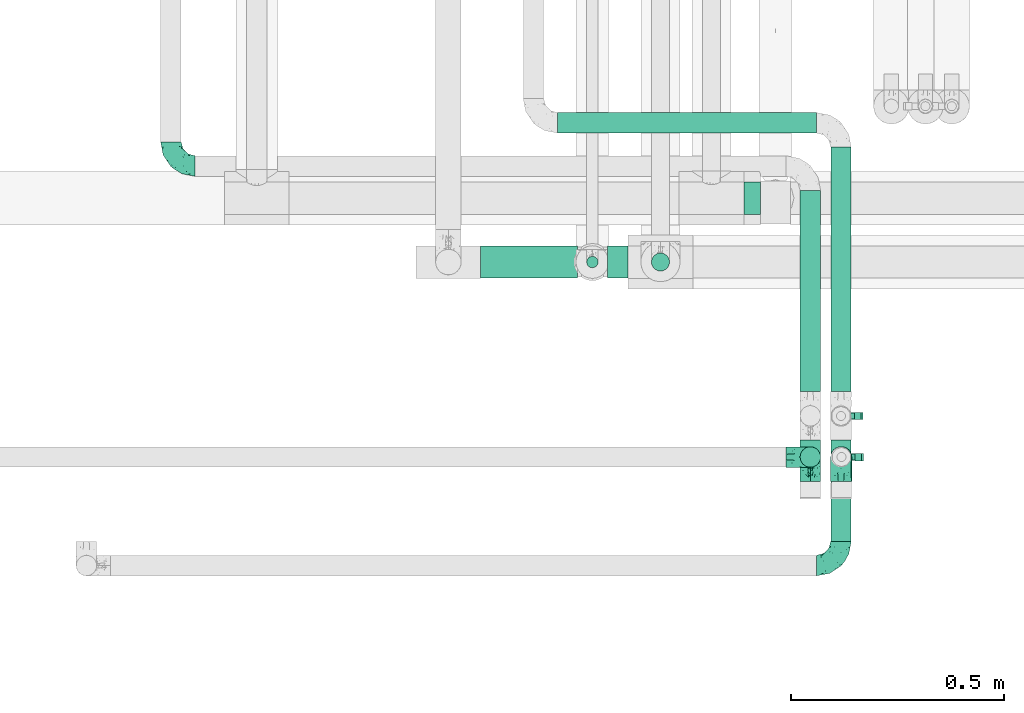
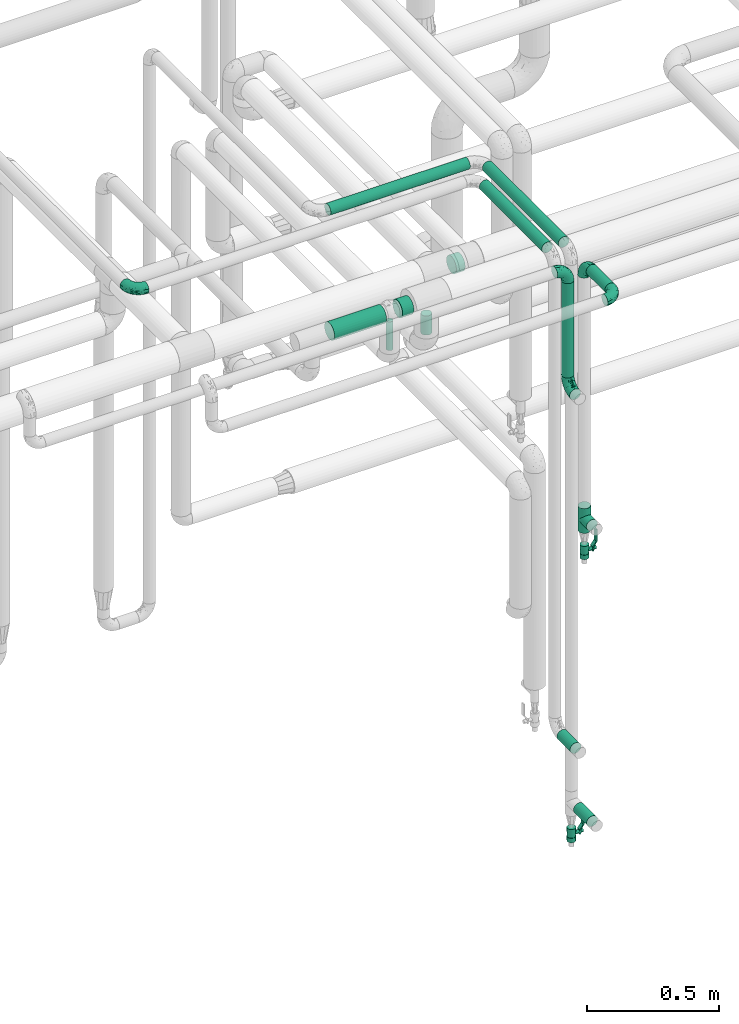
# One storey, part 689 of 827: 12 flow segments, 6 flow fittings, 2 flow controllers.
"""IFC2X3 building model written with IfcOpenShell, lengths in millimetres."""

from ifc_helpers import new_model, entity, si_unit, converted_unit, derived_unit, direction, frame, origin, origin_2d_with_axis, place, context, subcontext, project, spatial, polyline, circle, outline, extrude, faceted_brep, source, transform, mapped, material, material_list, type_object, type_shapes, element, save


model = new_model("IFC2X3")

# Units and contexts
model_context = context("Model", 3, precision=0.01, world=origin(), true_north=direction((6.12303176911189e-17, 1.0)))
body_context = subcontext(model_context, "Body", "Model", "MODEL_VIEW")
ifc_project = project(units=[si_unit("LENGTHUNIT", "METRE", prefix="MILLI"), si_unit("AREAUNIT", "SQUARE_METRE"), si_unit("VOLUMEUNIT", "CUBIC_METRE"), converted_unit("PLANEANGLEUNIT", "DEGREE", entity("IfcRatioMeasure", 0.0174532925199433), si_unit("PLANEANGLEUNIT", "RADIAN"), dimensions=[0, 0, 0, 0, 0, 0, 0]), si_unit("MASSUNIT", "GRAM", prefix="KILO"), derived_unit("MASSDENSITYUNIT", [(si_unit("MASSUNIT", "GRAM", prefix="KILO"), 1), (si_unit("LENGTHUNIT", "METRE"), -3)]), derived_unit("MOMENTOFINERTIAUNIT", [(si_unit("LENGTHUNIT", "METRE"), 4)]), si_unit("TIMEUNIT", "SECOND"), si_unit("FREQUENCYUNIT", "HERTZ"), si_unit("THERMODYNAMICTEMPERATUREUNIT", "DEGREE_CELSIUS"), derived_unit("THERMALTRANSMITTANCEUNIT", [(si_unit("MASSUNIT", "GRAM", prefix="KILO"), 1), (si_unit("THERMODYNAMICTEMPERATUREUNIT", "KELVIN"), -1), (si_unit("TIMEUNIT", "SECOND"), -3)]), derived_unit("VOLUMETRICFLOWRATEUNIT", [(si_unit("LENGTHUNIT", "METRE"), 3), (si_unit("TIMEUNIT", "SECOND"), -1)]), derived_unit("MASSFLOWRATEUNIT", [(si_unit("MASSUNIT", "GRAM", prefix="KILO"), 1), (si_unit("TIMEUNIT", "SECOND"), -1)]), derived_unit("ROTATIONALFREQUENCYUNIT", [(si_unit("TIMEUNIT", "SECOND"), -1)]), si_unit("ELECTRICCURRENTUNIT", "AMPERE"), si_unit("ELECTRICVOLTAGEUNIT", "VOLT"), si_unit("POWERUNIT", "WATT"), si_unit("FORCEUNIT", "NEWTON", prefix="KILO"), si_unit("ILLUMINANCEUNIT", "LUX"), si_unit("LUMINOUSFLUXUNIT", "LUMEN"), si_unit("LUMINOUSINTENSITYUNIT", "CANDELA"), derived_unit("USERDEFINED", [(si_unit("MASSUNIT", "GRAM", prefix="KILO"), -1), (si_unit("LENGTHUNIT", "METRE"), -2), (si_unit("TIMEUNIT", "SECOND"), 3), (si_unit("LUMINOUSFLUXUNIT", "LUMEN"), 1)]), derived_unit("LINEARVELOCITYUNIT", [(si_unit("LENGTHUNIT", "METRE"), 1), (si_unit("TIMEUNIT", "SECOND"), -1)]), si_unit("PRESSUREUNIT", "PASCAL"), derived_unit("USERDEFINED", [(si_unit("LENGTHUNIT", "METRE"), -2), (si_unit("MASSUNIT", "GRAM", prefix="KILO"), 1), (si_unit("TIMEUNIT", "SECOND"), -2)]), derived_unit("LINEARFORCEUNIT", [(si_unit("MASSUNIT", "GRAM", prefix="KILO"), 1), (si_unit("LENGTHUNIT", "METRE"), 1), (si_unit("TIMEUNIT", "SECOND"), -2), (si_unit("LENGTHUNIT", "METRE"), -1)]), derived_unit("PLANARFORCEUNIT", [(si_unit("MASSUNIT", "GRAM", prefix="KILO"), 1), (si_unit("LENGTHUNIT", "METRE"), 1), (si_unit("TIMEUNIT", "SECOND"), -2), (si_unit("LENGTHUNIT", "METRE"), -2)])], contexts=[model_context])

# Site, building, storey
site_placement = place(None, origin())
site = spatial("IfcSite", under=ifc_project, at=site_placement, CompositionType="ELEMENT")
building_placement = place(site_placement, origin())
building = spatial("IfcBuilding", under=site, at=building_placement, CompositionType="ELEMENT")
storey_placement = place(building_placement, frame((0.0, 0.0, 28200.0)))
storey = spatial("IfcBuildingStorey", under=building, at=storey_placement, Name="08", CompositionType="ELEMENT", Elevation=28200.0)

# Flow segments
pipe_segment_type = type_object("IfcPipeSegmentType", PredefinedType="NOTDEFINED")
flow_segment_1_placement = place(storey_placement, frame((54468.31, 15266.32, 2973.65)))
element("IfcFlowSegment", 1, at=flow_segment_1_placement, inside=storey, type_object=pipe_segment_type, context=body_context, shape_type="SweptSolid", body=[
    extrude(circle(Radius=24.0, at=origin_2d_with_axis()), frame((25.6, 0.0, 25.6), z_axis=(0.0, 1.0, 0.0), x_axis=(1.0, 0.0, 0.0)), (0.0, 0.0, 1.0), 141.000000000016),
])
flow_segment_2_placement = place(storey_placement, frame((53647.41, 15883.03, 2660.65)))
element("IfcFlowSegment", 2, at=flow_segment_2_placement, inside=storey, type_object=pipe_segment_type, context=body_context, shape_type="SweptSolid", body=[
    extrude(circle(Radius=37.75, at=origin_2d_with_axis()), frame((0.0, 39.35, 39.35), z_axis=(1.0, 0.0, 0.0), x_axis=(0.0, 1.0, 0.0)), (0.0, 0.0, 1.0), 227.379509999996),
])
flow_segment_3_placement = place(storey_placement, frame((54396.29, 15438.72, 2507.0)))
element("IfcFlowSegment", 3, at=flow_segment_3_placement, inside=storey, type_object=pipe_segment_type, context=body_context, shape_type="SweptSolid", body=[
    extrude(circle(Radius=24.0, at=origin_2d_with_axis()), frame((25.6, 25.6, 0.0)), (0.0, 0.0, 1.0), 435.248734871879),
])
flow_segment_4_placement = place(storey_placement, frame((53828.41, 16223.88, 2974.4)))
element("IfcFlowSegment", 4, at=flow_segment_4_placement, inside=storey, type_object=pipe_segment_type, context=body_context, shape_type="SweptSolid", body=[
    extrude(circle(Radius=24.0, at=origin_2d_with_axis()), frame((0.0, 25.6, 25.6), z_axis=(1.0, 0.0, 0.0), x_axis=(0.0, 1.0, 0.0)), (0.0, 0.0, 1.0), 608.500000000018),
])
flow_segment_5_placement = place(storey_placement, frame((53894.79, 15907.38, 2527.27)))
element("IfcFlowSegment", 5, at=flow_segment_5_placement, inside=storey, type_object=pipe_segment_type, context=body_context, shape_type="SweptSolid", body=[
    extrude(circle(Radius=13.4, at=origin_2d_with_axis()), frame((15.0, 15.0, 0.0)), (0.0, 0.0, 1.0), 132.730733342479),
])
flow_segment_6_placement = place(storey_placement, frame((53944.79, 15883.03, 2660.65)))
element("IfcFlowSegment", 6, at=flow_segment_6_placement, inside=storey, type_object=pipe_segment_type, context=body_context, shape_type="SweptSolid", body=[
    extrude(circle(Radius=37.75, at=origin_2d_with_axis()), frame((0.0, 39.35, 39.35), z_axis=(1.0, 0.0, 0.0), x_axis=(0.0, 1.0, 0.0)), (0.0, 0.0, 1.0), 49.0000000000149),
])
flow_segment_7_placement = place(storey_placement, frame((54047.04, 15899.63, 2548.0)))
element("IfcFlowSegment", 7, at=flow_segment_7_placement, inside=storey, type_object=pipe_segment_type, context=body_context, shape_type="SweptSolid", body=[
    extrude(circle(Radius=21.15, at=origin_2d_with_axis()), frame((22.75, 22.75, 0.0)), (0.0, 0.0, 1.0), 87.999999999941),
])
flow_segment_8_placement = place(storey_placement, frame((54265.79, 16033.03, 2660.69)))
element("IfcFlowSegment", 8, at=flow_segment_8_placement, inside=storey, type_object=pipe_segment_type, context=body_context, shape_type="SweptSolid", body=[
    extrude(circle(Radius=37.75, at=origin_2d_with_axis()), frame((0.0, 39.35, 39.35), z_axis=(1.0, 0.0, 0.0), x_axis=(0.0, -1.0, 0.0)), (0.0, 0.0, 1.0), 39.0000000000085),
])
flow_segment_9_placement = place(storey_placement, frame((54468.31, 15617.75, 2974.4)))
element("IfcFlowSegment", 9, at=flow_segment_9_placement, inside=storey, type_object=pipe_segment_type, context=body_context, shape_type="SweptSolid", body=[
    extrude(circle(Radius=24.0, at=origin_2d_with_axis()), frame((25.6, 0.0, 25.6), z_axis=(0.0, 1.0, 0.0), x_axis=(-1.0, 0.0, 0.0)), (0.0, 0.0, 1.0), 574.722828505507),
])
flow_segment_10_placement = place(storey_placement, frame((54396.29, 15618.03, 2974.4)))
element("IfcFlowSegment", 10, at=flow_segment_10_placement, inside=storey, type_object=pipe_segment_type, context=body_context, shape_type="SweptSolid", body=[
    extrude(circle(Radius=24.0, at=origin_2d_with_axis()), frame((25.6, 0.0, 25.6), z_axis=(0.0, 1.0, 0.0), x_axis=(-1.0, 0.0, 0.0)), (0.0, 0.0, 1.0), 472.904411024971),
])
flow_segment_11_placement = place(storey_placement, frame((54468.31, 15403.75, 431.9)))
element("IfcFlowSegment", 11, at=flow_segment_11_placement, inside=storey, type_object=pipe_segment_type, context=body_context, shape_type="SweptSolid", body=[
    extrude(circle(Radius=24.0, at=origin_2d_with_axis()), frame((25.6, 0.0, 25.6), z_axis=(0.0, 1.0, 0.0), x_axis=(-1.0, 0.0, 0.0)), (0.0, 0.0, 1.0), 100.000000000003),
])
flow_segment_12_placement = place(storey_placement, frame((54396.29, 15404.03, 794.4)))
element("IfcFlowSegment", 12, at=flow_segment_12_placement, inside=storey, type_object=pipe_segment_type, context=body_context, shape_type="SweptSolid", body=[
    extrude(circle(Radius=24.0, at=origin_2d_with_axis()), frame((25.6, 0.0, 25.6), z_axis=(0.0, 1.0, 0.0), x_axis=(-1.0, 0.0, 0.0)), (0.0, 0.0, 1.0), 100.000000000001),
])

# Flow controllers
ifc_material = material()
ifc_material_list = material_list([ifc_material, ifc_material, ifc_material, ifc_material, ifc_material])
valve_type = type_object("IfcValveType", PredefinedType="NOTDEFINED", material=ifc_material_list)
shared_shape_1 = source(origin(), body_context, "Body", "SweptSolid", [
    extrude(circle(Radius=17.5, at=origin_2d_with_axis()), frame((-30.5, 0.0, 0.0), z_axis=(1.0, 0.0, 0.0), x_axis=(0.0, 1.0, 0.0)), (0.0, 0.0, 1.0), 20.3333333333333),
    extrude(circle(Radius=16.0, at=origin_2d_with_axis()), frame((-10.17, 0.0, 0.0), z_axis=(1.0, 0.0, 0.0), x_axis=(0.0, 1.0, 0.0)), (0.0, 0.0, 1.0), 20.3333333333333),
    extrude(circle(Radius=17.5, at=origin_2d_with_axis()), frame((10.17, 0.0, 0.0), z_axis=(1.0, 0.0, 0.0), x_axis=(0.0, 1.0, 0.0)), (0.0, 0.0, 1.0), 20.3333333333333),
    extrude(outline(polyline([(-38.75, -5.0), (-38.75, -10.0), (-17.92, -10.0), (2.08, 5.0), (56.25, 5.0), (56.25, 10.0), (0.42, 10.0), (-19.58, -5.0), (-38.75, -5.0)])), frame((28.75, -8.75, 41.5), z_axis=(0.0, -1.0, 0.0), x_axis=(1.0, 0.0, 0.0)), (0.0, 0.0, -1.0), 17.5),
    extrude(circle(Radius=8.0, at=origin_2d_with_axis()), origin(), (0.0, 0.0, 1.0), 49.0),
])
type_shapes(valve_type, [shared_shape_1])
for number, where, z_axis, x_axis in (
    (13, (54495.13, 15464.32, 1669.0), (1.0, 0.0, 0.0), (0.0, 0.0, 1.0)),
    (14, (54493.91, 15560.75, 305.0), (1.0, 0.0, 0.0), (0.0, 0.0, 1.0)),
):
    element("IfcFlowController", number, at=place(storey_placement, frame(where, z_axis=z_axis, x_axis=x_axis)), inside=storey, type_object=valve_type, material=ifc_material, context=body_context, shape_type="MappedRepresentation", body=[
        mapped(shared_shape_1, transform((0.0, 0.0, 0.0), scale=1.0)),
    ])

# Flow fittings
pipe_fitting_type_1 = type_object("IfcPipeFittingType", Name="ADSK_1", PredefinedType="NOTDEFINED", material=ifc_material)
shared_shape_2 = source(origin(), body_context, "Body", "Brep", [
    faceted_brep([(-57.0, 12.07, -20.91), (-57.0, 6.25, -23.33), (-57.0, 0.0, -24.15), (-57.0, -6.25, -23.33), (-57.0, -12.08, -20.91), (-57.0, -17.08, -17.08), (-57.0, -20.91, -12.08), (-57.0, -23.33, -6.25), (-57.0, -24.15, 0.0), (-57.0, -23.33, 6.25), (-57.0, -20.91, 12.07), (-57.0, -17.08, 17.08), (-57.0, -12.08, 20.91), (-57.0, -6.25, 23.33), (-57.0, 0.0, 24.15), (-57.0, 6.25, 23.33), (-57.0, 12.07, 20.91), (-57.0, 17.08, 17.08), (-57.0, 20.91, 12.07), (-57.0, 23.33, 6.25), (-57.0, 24.15, 0.0), (-57.0, 23.33, -6.25), (-57.0, 20.91, -12.08), (-57.0, 17.08, -17.08), (0.0, 57.0, -24.15), (-6.25, 57.0, -23.33), (-12.07, 57.0, -20.91), (-17.08, 57.0, -17.08), (-20.91, 57.0, -12.08), (-23.33, 57.0, -6.25), (-24.15, 57.0, 0.0), (-23.33, 57.0, 6.25), (-20.91, 57.0, 12.07), (-17.08, 57.0, 17.08), (-12.07, 57.0, 20.91), (-6.25, 57.0, 23.33), (0.0, 57.0, 24.15), (6.25, 57.0, 23.33), (12.08, 57.0, 20.91), (17.08, 57.0, 17.08), (20.91, 57.0, 12.07), (23.33, 57.0, 6.25), (24.15, 57.0, 0.0), (23.33, 57.0, -6.25), (20.91, 57.0, -12.08), (17.08, 57.0, -17.08), (12.08, 57.0, -20.91), (6.25, 57.0, -23.33), (14.9, 21.14, 6.17), (13.61, 24.64, 12.48), (6.23, 8.95, 8.98), (-41.47, -21.06, 0.0), (-41.92, -18.38, 13.72), (-24.64, -13.61, 12.48), (-37.37, -13.24, 18.15), (-6.8, -4.93, 8.18), (-21.76, -15.19, 6.22), (-12.78, -9.18, 0.0), (-37.73, -20.51, 7.75), (-7.38, 7.38, 20.24), (-23.37, -4.26, 20.42), (-11.9, -3.19, 15.86), (-42.14, -8.7, 21.82), (13.24, 37.37, 18.15), (9.33, 23.53, 16.85), (4.26, 23.37, 20.42), (2.77, 10.92, 15.55), (-29.46, 0.91, 23.52), (-44.13, 20.56, 15.69), (-39.25, 26.33, 10.88), (-49.02, 22.92, 9.96), (-34.58, 23.87, 17.15), (-15.8, 6.8, 22.81), (-8.67, 20.47, 23.88), (-18.12, 12.9, 24.08), (-48.29, 14.92, 19.65), (-44.06, -2.85, 23.78), (-9.23, 48.95, 22.58), (-3.78, 42.74, 24.07), (-40.34, 4.26, 24.09), (-44.02, 26.14, 5.46), (-44.04, 9.88, 22.74), (-4.95, 16.87, 22.52), (-2.75, 1.43, 12.5), (-25.48, 40.98, 10.71), (20.51, 37.73, 7.75), (18.38, 41.92, 13.72), (8.7, 42.14, 21.82), (-25.95, -17.97, 0.0), (2.85, 44.06, 23.78), (21.06, 41.47, 0.0), (17.97, 25.95, 0.0), (-24.04, -9.27, 17.13), (-33.26, 33.26, 5.86), (-28.55, 40.57, 0.0), (-40.57, 28.55, 0.0), (-25.29, 47.19, 4.06), (-27.01, 31.1, 16.77), (-15.7, 43.95, 19.9), (-20.27, 45.22, 15.61), (-30.53, 31.98, 12.64), (-11.28, 38.33, 22.92), (-9.97, 27.88, 24.09), (-20.15, 30.26, 21.25), (-31.25, 11.75, 23.64), (-28.75, 7.23, 24.15), (-29.53, 18.06, 22.27), (-28.44, 24.21, 20.02), (-37.55, 17.7, 20.26), (-15.88, 29.25, 22.99), (-20.82, 20.82, 23.44), (-0.91, 29.46, 23.52), (-13.5, -7.67, 12.04), (1.49, 1.56, 5.16), (8.86, 10.35, 4.59), (0.38, -0.38, 0.0), (9.18, 12.78, 0.0), (-37.37, -13.24, -18.15), (8.86, 10.35, -4.59), (-45.22, 20.27, -15.61), (-43.95, 15.7, -19.9), (-38.33, 11.28, -22.92), (-48.95, 9.23, -22.58), (-47.19, 25.29, -4.06), (-33.26, 33.26, -5.86), (18.38, 41.92, -13.72), (-30.26, 20.15, -21.25), (2.85, 44.06, -23.78), (-4.26, 40.34, -24.09), (-40.98, 25.48, -10.71), (-41.92, -18.38, -13.72), (9.25, 23.5, -16.92), (4.26, 23.37, -20.42), (13.24, 37.37, -18.15), (-37.73, -20.51, -7.75), (-11.75, 31.25, -23.64), (-7.23, 28.75, -24.15), (-12.9, 18.12, -24.08), (8.7, 42.14, -21.82), (-44.06, -2.85, -23.78), (-6.8, 15.8, -22.81), (-20.47, 8.67, -23.88), (-24.64, -13.61, -12.48), (-42.74, 3.78, -24.07), (-18.06, 29.53, -22.27), (-24.21, 28.44, -20.02), (-27.88, 9.97, -24.09), (-31.1, 27.01, -16.77), (-26.14, 44.02, -5.46), (14.9, 21.14, -6.17), (20.51, 37.73, -7.75), (-9.88, 44.04, -22.74), (-20.56, 44.13, -15.69), (-21.76, -15.19, -6.22), (-13.5, -7.67, -12.04), (-24.14, -9.76, -16.74), (-11.9, -3.19, -15.86), (-14.92, 48.29, -19.65), (-23.37, -4.26, -20.42), (-0.91, 29.46, -23.52), (-26.33, 39.25, -10.88), (-23.87, 34.58, -17.15), (-42.14, -8.7, -21.82), (-22.92, 49.02, -9.96), (13.61, 24.64, -12.48), (-31.98, 30.53, -12.64), (-16.87, 4.95, -22.52), (-17.7, 37.55, -20.26), (-29.25, 15.88, -22.99), (-20.82, 20.82, -23.44), (-29.46, 0.91, -23.52), (-7.38, 7.38, -20.24), (2.77, 10.92, -15.55), (6.23, 8.95, -8.98), (-6.8, -4.93, -8.18), (-2.81, 1.41, -12.54), (1.49, 1.56, -5.16)], [[[0, 1, 2, 3, 4, 5, 6, 7, 8, 9, 10, 11, 12, 13, 14, 15, 16, 17, 18, 19, 20, 21, 22, 23]], [[24, 25, 26, 27, 28, 29, 30, 31, 32, 33, 34, 35, 36, 37, 38, 39, 40, 41, 42, 43, 44, 45, 46, 47]], [[48, 49, 50]], [[9, 8, 51]], [[52, 53, 54]], [[55, 56, 57]], [[10, 58, 52]], [[9, 58, 10]], [[59, 60, 61]], [[54, 12, 11]], [[54, 62, 12]], [[63, 39, 38]], [[64, 65, 66]], [[62, 60, 67]], [[68, 69, 70]], [[71, 69, 68]], [[72, 73, 74]], [[16, 75, 17]], [[13, 76, 14]], [[35, 77, 78]], [[14, 79, 15]], [[17, 68, 18]], [[14, 76, 79]], [[20, 19, 80]], [[70, 19, 18]], [[81, 15, 79]], [[15, 81, 16]], [[73, 72, 82]], [[66, 83, 50]], [[32, 31, 84]], [[85, 86, 49]], [[63, 87, 65]], [[56, 58, 88]], [[36, 89, 37]], [[85, 41, 40]], [[36, 35, 78]], [[90, 41, 85]], [[40, 39, 86]], [[12, 62, 13]], [[86, 85, 40]], [[48, 85, 49]], [[85, 91, 90]], [[87, 38, 37]], [[92, 60, 54]], [[80, 69, 93]], [[93, 94, 95]], [[10, 52, 11]], [[94, 96, 30]], [[97, 98, 99]], [[80, 93, 95]], [[100, 97, 84]], [[99, 98, 33]], [[101, 102, 78]], [[103, 101, 98]], [[96, 31, 30]], [[77, 98, 101]], [[77, 35, 34]], [[34, 33, 98]], [[9, 51, 58]], [[87, 63, 38]], [[104, 105, 74]], [[106, 103, 107]], [[106, 81, 104]], [[75, 68, 17]], [[108, 107, 71]], [[33, 32, 99]], [[109, 103, 110]], [[101, 109, 102]], [[89, 78, 111]], [[53, 52, 58]], [[54, 11, 52]], [[60, 62, 54]], [[88, 58, 51]], [[76, 62, 67]], [[53, 112, 92]], [[60, 59, 72]], [[39, 63, 86]], [[49, 86, 63]], [[89, 87, 37]], [[42, 41, 90]], [[111, 82, 65]], [[111, 65, 87]], [[65, 59, 66]], [[104, 81, 79]], [[75, 81, 108]], [[32, 84, 99]], [[97, 99, 84]], [[98, 97, 103]], [[106, 107, 108]], [[74, 102, 110]], [[111, 78, 102]], [[74, 110, 104]], [[74, 67, 72]], [[61, 92, 112]], [[66, 59, 61]], [[56, 53, 58]], [[66, 50, 49]], [[61, 112, 83]], [[66, 49, 64]], [[78, 89, 36]], [[87, 89, 111]], [[62, 76, 13]], [[79, 76, 67]], [[100, 93, 69]], [[96, 93, 84]], [[55, 113, 50]], [[113, 114, 50]], [[104, 79, 105]], [[106, 104, 110]], [[20, 80, 95]], [[85, 48, 91]], [[115, 114, 113]], [[116, 91, 48]], [[70, 80, 19]], [[93, 96, 94]], [[84, 31, 96]], [[103, 106, 110]], [[81, 106, 108]], [[103, 97, 107]], [[71, 107, 97]], [[71, 97, 100]], [[108, 71, 68]], [[79, 67, 105]], [[67, 74, 105]], [[115, 113, 57]], [[112, 56, 55]], [[56, 88, 57]], [[60, 72, 67]], [[82, 72, 59]], [[65, 82, 59]], [[82, 111, 73]], [[111, 102, 73]], [[102, 74, 73]], [[81, 75, 16]], [[68, 75, 108]], [[68, 70, 18]], [[80, 70, 69]], [[98, 77, 34]], [[78, 77, 101]], [[93, 100, 84]], [[71, 100, 69]], [[102, 109, 110]], [[101, 103, 109]], [[53, 92, 54]], [[61, 60, 92]], [[56, 112, 53]], [[83, 112, 55]], [[50, 83, 55]], [[61, 83, 66]], [[49, 63, 64]], [[65, 64, 63]], [[57, 113, 55]], [[114, 115, 116]], [[116, 48, 114]], [[48, 50, 114]], [[117, 5, 4]], [[116, 115, 118]], [[119, 120, 23]], [[121, 122, 120]], [[95, 123, 20]], [[0, 23, 120]], [[124, 95, 94]], [[125, 45, 44]], [[121, 120, 126]], [[24, 127, 128]], [[22, 21, 129]], [[0, 122, 1]], [[5, 117, 130]], [[131, 132, 133]], [[134, 88, 51]], [[135, 136, 137]], [[6, 5, 130]], [[46, 138, 47]], [[139, 3, 2]], [[140, 141, 137]], [[6, 134, 7]], [[134, 130, 142]], [[143, 2, 1]], [[144, 126, 145]], [[121, 146, 143]], [[147, 120, 119]], [[94, 148, 124]], [[149, 150, 91]], [[30, 29, 148]], [[151, 25, 128]], [[27, 152, 28]], [[134, 153, 88]], [[154, 155, 156]], [[27, 26, 157]], [[151, 26, 25]], [[155, 158, 156]], [[24, 47, 127]], [[1, 122, 143]], [[138, 132, 159]], [[160, 152, 161]], [[24, 128, 25]], [[46, 133, 138]], [[162, 117, 4]], [[148, 160, 124]], [[152, 160, 163]], [[154, 142, 155]], [[45, 125, 133]], [[133, 46, 45]], [[125, 164, 133]], [[51, 7, 134]], [[42, 90, 43]], [[165, 147, 129]], [[153, 134, 142]], [[43, 150, 44]], [[162, 4, 3]], [[141, 140, 166]], [[117, 162, 158]], [[163, 29, 28]], [[43, 90, 150]], [[123, 21, 20]], [[144, 151, 135]], [[157, 152, 27]], [[167, 145, 161]], [[23, 22, 119]], [[168, 126, 169]], [[121, 168, 146]], [[139, 143, 170]], [[142, 130, 117]], [[8, 7, 51]], [[134, 6, 130]], [[139, 162, 3]], [[170, 166, 158]], [[170, 158, 162]], [[158, 171, 156]], [[44, 150, 125]], [[91, 150, 90]], [[164, 125, 150]], [[132, 138, 133]], [[127, 138, 159]], [[131, 164, 172]], [[132, 171, 140]], [[135, 151, 128]], [[157, 151, 167]], [[22, 129, 119]], [[147, 119, 129]], [[120, 147, 126]], [[144, 145, 167]], [[137, 146, 169]], [[170, 143, 146]], [[137, 169, 135]], [[137, 159, 140]], [[171, 172, 156]], [[173, 174, 175]], [[156, 175, 154]], [[174, 57, 153]], [[132, 172, 171]], [[172, 164, 173]], [[143, 139, 2]], [[162, 139, 170]], [[138, 127, 47]], [[128, 127, 159]], [[165, 124, 160]], [[123, 124, 129]], [[149, 173, 164]], [[176, 174, 173]], [[135, 128, 136]], [[144, 135, 169]], [[150, 149, 164]], [[176, 118, 115]], [[149, 91, 116]], [[30, 148, 94]], [[163, 148, 29]], [[124, 123, 95]], [[129, 21, 123]], [[126, 144, 169]], [[151, 144, 167]], [[126, 147, 145]], [[161, 145, 147]], [[161, 147, 165]], [[167, 161, 152]], [[128, 159, 136]], [[159, 137, 136]], [[154, 153, 142]], [[132, 140, 159]], [[174, 176, 57]], [[57, 88, 153]], [[166, 140, 171]], [[158, 166, 171]], [[166, 170, 141]], [[170, 146, 141]], [[146, 137, 141]], [[151, 157, 26]], [[152, 157, 167]], [[152, 163, 28]], [[148, 163, 160]], [[120, 122, 0]], [[143, 122, 121]], [[124, 165, 129]], [[161, 165, 160]], [[146, 168, 169]], [[121, 126, 168]], [[142, 117, 155]], [[158, 155, 117]], [[175, 156, 172]], [[153, 154, 174]], [[173, 175, 172]], [[174, 154, 175]], [[164, 131, 133]], [[172, 132, 131]], [[176, 173, 118]], [[57, 176, 115]], [[173, 149, 118]], [[149, 116, 118]]]),
])
type_shapes(pipe_fitting_type_1, [shared_shape_2])
flow_fitting_1_placement = place(storey_placement, frame((54493.91, 15209.32, 2999.25)))
element("IfcFlowFitting", 15, at=flow_fitting_1_placement, inside=storey, type_object=pipe_fitting_type_1, material=ifc_material, Name="ADSK_1", ObjectType="ADSK_1", context=body_context, shape_type="MappedRepresentation", body=[
    mapped(shared_shape_2, transform((0.0, 0.0, 0.0), scale=1.0)),
])
for number, where, z_axis, x_axis, name in (
    (16, (52919.38, 16147.94, 3000.0), (0.0, 0.0, 1.0), (0.0, -1.0, 0.0), "ADSK_1"),
    (17, (54421.88, 15464.32, 2999.25), (0.0, 1.0, 0.0), (1.0, 0.0, 0.0), "ADSK_1"),
    (18, (54421.88, 15464.32, 2450.0), (-1.0, 0.0, 0.0), (0.0, 0.0, -1.0), "ADSK_1"),
    (19, (54493.91, 15464.32, 2999.25), (-1.0, 0.0, 0.0), (0.0, 1.0, 0.0), "ADSK_1"),
):
    element("IfcFlowFitting", number, at=place(storey_placement, frame(where, z_axis=z_axis, x_axis=x_axis)), inside=storey, type_object=pipe_fitting_type_1, material=ifc_material, Name=name, ObjectType="ADSK_1", context=body_context, shape_type="MappedRepresentation", body=[
        mapped(shared_shape_2, transform((0.0, 0.0, 0.0), scale=1.0)),
    ])
pipe_fitting_type_2 = type_object("IfcPipeFittingType", Name="ADSK_1", PredefinedType="NOTDEFINED", material=ifc_material)
shared_shape_3 = source(origin(), body_context, "Body", "Brep", [
    faceted_brep([(-57.0, 12.07, -20.91), (-57.0, 6.25, -23.33), (-57.0, 0.0, -24.15), (-57.0, -6.25, -23.33), (-57.0, -12.08, -20.91), (-57.0, -17.08, -17.08), (-57.0, -20.91, -12.08), (-57.0, -23.33, -6.25), (-57.0, -24.15, 0.0), (-57.0, -23.33, 6.25), (-57.0, -20.91, 12.07), (-57.0, -17.08, 17.08), (-57.0, -12.08, 20.91), (-57.0, -6.25, 23.33), (-57.0, 0.0, 24.15), (-57.0, 6.25, 23.33), (-57.0, 12.07, 20.91), (-57.0, 17.08, 17.08), (-57.0, 20.91, 12.07), (-57.0, 23.33, 6.25), (-57.0, 24.15, 0.0), (-57.0, 23.33, -6.25), (-57.0, 20.91, -12.08), (-57.0, 17.08, -17.08), (57.0, 0.0, -24.15), (57.0, 6.25, -23.33), (57.0, 12.07, -20.91), (57.0, 17.08, -17.08), (57.0, 20.91, -12.08), (57.0, 23.33, -6.25), (57.0, 24.15, 0.0), (57.0, 23.33, 6.25), (57.0, 20.91, 12.07), (57.0, 17.08, 17.08), (57.0, 12.07, 20.91), (57.0, 6.25, 23.33), (57.0, 0.0, 24.15), (57.0, -6.25, 23.33), (57.0, -12.08, 20.91), (57.0, -17.08, 17.08), (57.0, -20.91, 12.07), (57.0, -23.33, 6.25), (57.0, -24.15, 0.0), (57.0, -23.33, -6.25), (57.0, -20.91, -12.08), (57.0, -17.08, -17.08), (57.0, -12.08, -20.91), (57.0, -6.25, -23.33), (23.27, -23.27, 6.45), (24.15, -24.15, 0.0), (-24.15, -24.15, 0.0), (20.9, -20.9, 12.1), (13.54, -13.54, 20.0), (17.52, -17.52, 16.62), (-23.27, -23.27, 6.45), (-20.9, -20.9, 12.1), (-17.52, -17.52, 16.62), (-13.54, -13.54, 20.0), (-9.19, -9.19, 22.33), (9.19, -9.19, 22.33), (4.64, -4.64, 23.7), (0.0, 0.0, 24.15), (-4.64, -4.64, 23.7), (4.64, -4.64, -23.7), (0.0, 0.0, -24.15), (-4.64, -4.64, -23.7), (-9.19, -9.19, -22.33), (9.19, -9.19, -22.33), (13.54, -13.54, -20.0), (17.52, -17.52, -16.62), (20.9, -20.9, -12.1), (23.27, -23.27, -6.45), (-13.54, -13.54, -20.0), (-17.52, -17.52, -16.62), (-23.27, -23.27, -6.45), (-20.9, -20.9, -12.1), (0.0, -57.0, -24.15), (6.25, -57.0, -23.33), (12.08, -57.0, -20.91), (17.08, -57.0, -17.08), (20.91, -57.0, -12.08), (23.33, -57.0, -6.25), (24.15, -57.0, 0.0), (23.33, -57.0, 6.25), (20.91, -57.0, 12.07), (17.08, -57.0, 17.08), (12.08, -57.0, 20.91), (6.25, -57.0, 23.33), (0.0, -57.0, 24.15), (-6.25, -57.0, 23.33), (-12.07, -57.0, 20.91), (-17.08, -57.0, 17.08), (-20.91, -57.0, 12.07), (-23.33, -57.0, 6.25), (-24.15, -57.0, 0.0), (-23.33, -57.0, -6.25), (-20.91, -57.0, -12.08), (-17.08, -57.0, -17.08), (-12.07, -57.0, -20.91), (-6.25, -57.0, -23.33)], [[[0, 1, 2, 3, 4, 5, 6, 7, 8, 9, 10, 11, 12, 13, 14, 15, 16, 17, 18, 19, 20, 21, 22, 23]], [[24, 25, 26, 27, 28, 29, 30, 31, 32, 33, 34, 35, 36, 37, 38, 39, 40, 41, 42, 43, 44, 45, 46, 47]], [[41, 40, 48]], [[42, 41, 49]], [[50, 9, 8]], [[49, 41, 48]], [[40, 51, 48]], [[39, 38, 52]], [[51, 40, 53]], [[52, 53, 39]], [[53, 40, 39]], [[50, 54, 9]], [[9, 54, 10]], [[54, 55, 10]], [[56, 57, 11]], [[11, 10, 56]], [[11, 57, 12]], [[56, 10, 55]], [[12, 57, 58]], [[52, 38, 59]], [[60, 36, 61]], [[62, 61, 14]], [[59, 37, 60]], [[37, 59, 38]], [[60, 37, 36]], [[61, 36, 35, 15, 14]], [[32, 31, 19, 18]], [[17, 16, 34, 33]], [[18, 17, 33, 32]], [[35, 34, 16, 15]], [[20, 19, 31, 30]], [[62, 13, 58]], [[13, 62, 14]], [[58, 13, 12]], [[27, 23, 22, 28]], [[22, 21, 29, 28]], [[0, 23, 27, 26]], [[20, 30, 29, 21]], [[24, 47, 63]], [[24, 64, 2, 1, 25]], [[64, 24, 63]], [[2, 64, 65]], [[26, 25, 1, 0]], [[65, 66, 3]], [[2, 65, 3]], [[66, 4, 3]], [[63, 47, 67]], [[46, 45, 68]], [[69, 68, 45]], [[44, 70, 69]], [[69, 45, 44]], [[46, 68, 67]], [[43, 42, 49]], [[7, 50, 8]], [[43, 71, 44]], [[71, 43, 49]], [[44, 71, 70]], [[72, 4, 66]], [[72, 5, 4]], [[5, 72, 73]], [[5, 73, 6]], [[74, 50, 7]], [[75, 74, 6]], [[74, 7, 6]], [[75, 6, 73]], [[46, 67, 47]], [[76, 77, 78, 79, 80, 81, 82, 83, 84, 85, 86, 87, 88, 89, 90, 91, 92, 93, 94, 95, 96, 97, 98, 99]], [[50, 94, 93]], [[54, 50, 93]], [[91, 90, 57]], [[56, 92, 91]], [[54, 93, 92]], [[58, 90, 89]], [[55, 54, 92]], [[56, 55, 92]], [[58, 57, 90]], [[88, 61, 62]], [[58, 89, 62]], [[56, 91, 57]], [[62, 89, 88]], [[60, 88, 87]], [[86, 59, 87]], [[84, 83, 48]], [[53, 85, 84]], [[52, 86, 85]], [[49, 83, 82]], [[59, 60, 87]], [[52, 59, 86]], [[49, 48, 83]], [[51, 53, 84]], [[48, 51, 84]], [[52, 85, 53]], [[88, 60, 61]], [[82, 81, 49]], [[71, 49, 81]], [[69, 80, 79]], [[79, 78, 68]], [[71, 81, 80]], [[67, 78, 77]], [[70, 71, 80]], [[69, 70, 80]], [[67, 68, 78]], [[76, 64, 63]], [[67, 77, 63]], [[69, 79, 68]], [[63, 77, 76]], [[65, 76, 99]], [[98, 66, 99]], [[96, 95, 74]], [[73, 97, 96]], [[72, 98, 97]], [[50, 95, 94]], [[66, 65, 99]], [[72, 66, 98]], [[50, 74, 95]], [[75, 73, 96]], [[74, 75, 96]], [[72, 97, 73]], [[76, 65, 64]]]),
])
type_shapes(pipe_fitting_type_2, [shared_shape_3])
flow_fitting_2_placement = place(storey_placement, frame((54495.13, 15464.32, 1821.5), z_axis=(1.0, 0.0, 0.0), x_axis=(0.0, 0.0, -1.0)))
element("IfcFlowFitting", 20, at=flow_fitting_2_placement, inside=storey, type_object=pipe_fitting_type_2, material=ifc_material, Name="ADSK_1", ObjectType="ADSK_1", context=body_context, shape_type="MappedRepresentation", body=[
    mapped(shared_shape_3, transform((0.0, 0.0, 0.0), scale=1.0)),
])

save(model, "model.ifc")
